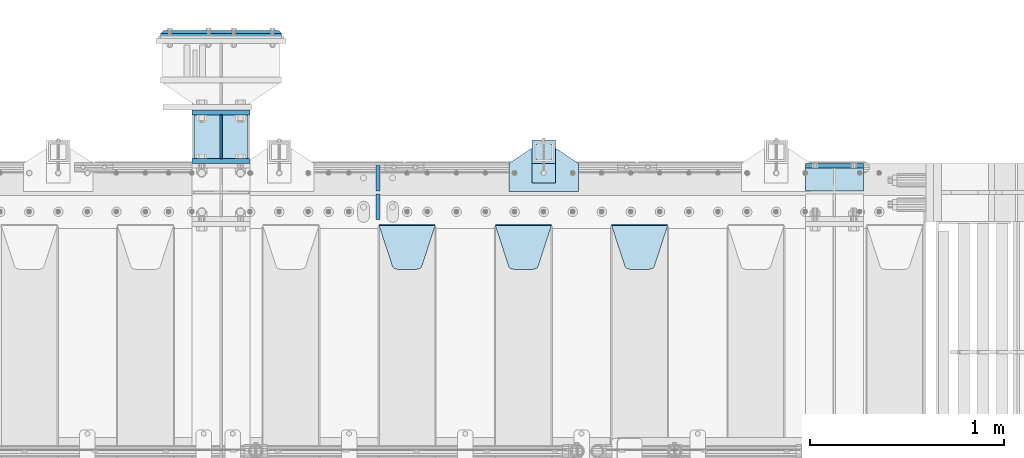
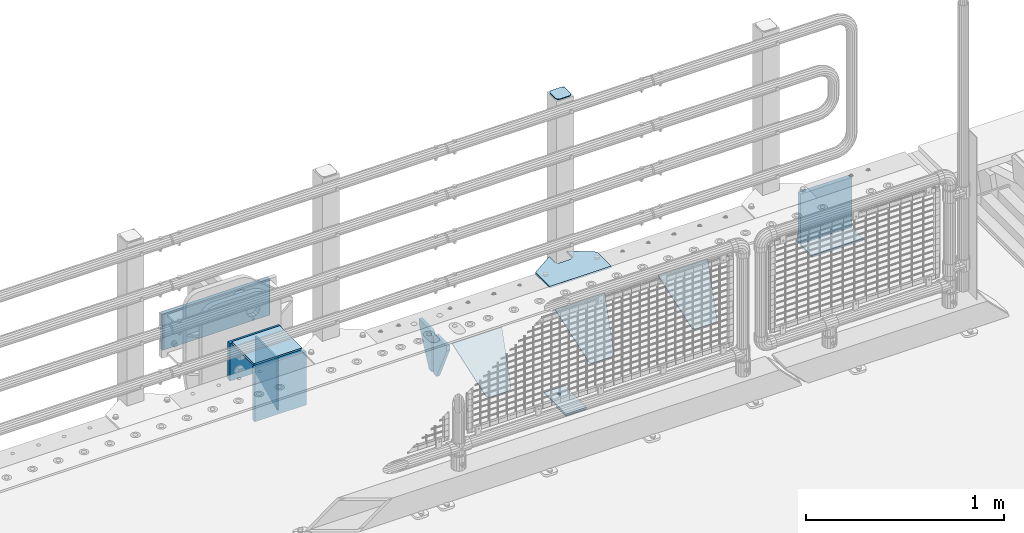
# One storey, part 226 of 240: 16 plates.
"""IFC2X3 building model written with IfcOpenShell, lengths in millimetres."""

from ifc_helpers import new_model, si_unit, frame, origin_with_axes, place, context, subcontext, project, spatial, faceted_brep, material, type_object, element, save


model = new_model("IFC2X3")

# Units and contexts
model_context = context("Model", 3, precision=1e-05, world=origin_with_axes())
body_context = subcontext(model_context, "Body", "Model", "MODEL_VIEW")
ifc_project = project(units=[si_unit("LENGTHUNIT", "METRE", prefix="MILLI"), si_unit("AREAUNIT", "SQUARE_METRE"), si_unit("VOLUMEUNIT", "CUBIC_METRE"), si_unit("MASSUNIT", "GRAM", prefix="KILO"), si_unit("TIMEUNIT", "SECOND"), si_unit("PLANEANGLEUNIT", "RADIAN"), si_unit("SOLIDANGLEUNIT", "STERADIAN"), si_unit("THERMODYNAMICTEMPERATUREUNIT", "DEGREE_CELSIUS"), si_unit("LUMINOUSINTENSITYUNIT", "LUMEN")], contexts=[model_context])

# Site, building, storey
site_placement = place(None, origin_with_axes())
site = spatial("IfcSite", under=ifc_project, at=site_placement, CompositionType="ELEMENT")
building_placement = place(site_placement, origin_with_axes())
building = spatial("IfcBuilding", under=site, at=building_placement, Name="Standard", CompositionType="ELEMENT")
storey_placement = place(building_placement, origin_with_axes())
storey = spatial("IfcBuildingStorey", under=building, at=storey_placement, Name="Undefined", CompositionType="ELEMENT", Elevation=0.0)

# Plates
ifc_material_1 = material(Name="STEEL/S355N")
plate_type_1 = type_object("IfcPlateType", PredefinedType="NOTDEFINED")
plate_1_placement = place(storey_placement, frame((55855.0, 36137.5, -339.999999999995), z_axis=(0.0, 0.0, 1.0), x_axis=(1.0, 0.0, 0.0)))
element("IfcPlate", 1, at=plate_1_placement, inside=storey, type_object=plate_type_1, material=ifc_material_1, context=body_context, shape_type="Brep", body=[
    faceted_brep([(0.0, -12.5, 0.0), (0.0, -12.5, 310.0), (0.0, 12.5, 310.0), (0.0, 12.5, 0.0), (300.0, -12.5, 310.0), (300.0, 12.5, 310.0), (300.0, -12.5, 0.0), (300.0, 12.5, 0.0)], [[[0, 1, 2, 3]], [[1, 4, 5, 2]], [[4, 6, 7, 5]], [[6, 0, 3, 7]], [[5, 7, 3, 2]], [[6, 4, 1, 0]]]),
])
plate_2_placement = place(storey_placement, frame((52690.0, 36162.5000000345, -340.000018222274), z_axis=(0.0, 0.0, 1.0), x_axis=(1.0, 0.0, 0.0)))
element("IfcPlate", 2, at=plate_2_placement, inside=storey, type_object=plate_type_1, material=ifc_material_1, context=body_context, shape_type="Brep", body=[
    faceted_brep([(0.0, -12.5, 0.0), (0.0, -12.5, 330.0), (0.0, 12.5, 330.0), (0.0, 12.5, 0.0), (300.0, -12.5, 330.0), (300.0, 12.5, 330.0), (300.0, -12.5, 0.0), (300.0, 12.5, 0.0)], [[[0, 1, 2, 3]], [[1, 4, 5, 2]], [[4, 6, 7, 5]], [[6, 0, 3, 7]], [[5, 7, 3, 2]], [[6, 4, 1, 0]]]),
])
plate_type_2 = type_object("IfcPlateType", PredefinedType="NOTDEFINED")
plate_3_placement = place(storey_placement, frame((55855.0, 36008.0, -342.999999999995), z_axis=(0.0, 1.0, 0.0), x_axis=(1.0, 0.0, 0.0)))
element("IfcPlate", 3, at=plate_3_placement, inside=storey, type_object=plate_type_2, material=ifc_material_1, context=body_context, shape_type="Brep", body=[
    faceted_brep([(0.0, -7.0, 0.0), (0.0, -7.0, 117.0), (0.0, 7.0, 117.0), (0.0, 7.0, 0.0), (300.0, -7.0, 117.0), (300.0, 7.0, 117.0), (300.0, -7.0, 0.0), (300.0, 7.0, 0.0)], [[[0, 1, 2, 3]], [[1, 4, 5, 2]], [[4, 6, 7, 5]], [[6, 0, 3, 7]], [[5, 7, 3, 2]], [[6, 4, 1, 0]]]),
])
plate_type_3 = type_object("IfcPlateType", PredefinedType="NOTDEFINED")
plate_4_placement = place(storey_placement, frame((54855.0, 35831.767766956, -1.76776695296758), z_axis=(0.0, -0.707106781186547, -0.707106781186548), x_axis=(1.0, 0.0, 0.0)))
element("IfcPlate", 4, at=plate_4_placement, inside=storey, type_object=plate_type_3, material=ifc_material_1, context=body_context, shape_type="Brep", body=[
    faceted_brep([(0.0, -2.5, 0.0), (69.345504679477, -2.50000000000364, 300.171731424827), (69.345504679477, 2.49999999999636, 300.171731424827), (0.0, 2.5, 0.0), (70.927406119954, -2.50000000000364, 304.897442415397), (70.927406119954, 2.49999999999636, 304.897442415397), (73.3818627772271, -2.50000000000728, 309.234538108525), (73.3818627772271, 2.49999999999636, 309.234538108529), (76.6187032999587, -2.50000000000728, 313.023683126099), (76.6187032999587, 2.49999999999636, 313.023683126103), (80.5190132705029, -2.50000000000364, 316.125672595368), (80.5190132705029, 2.49999999999636, 316.125672595368), (84.9395038596849, -2.50000000000364, 318.426546230472), (84.9395038596849, 2.49999999999636, 318.426546230472), (89.7177759439219, -2.5, 319.841774983277), (89.7177759439219, 2.49999999999636, 319.841774983273), (94.6782862926484, -2.50000000000364, 320.319366455074), (94.6782862926484, 2.49999999999636, 320.319366455074), (195.321713707352, -2.50000000000364, 320.319366455074), (195.321713707352, 2.49999999999636, 320.319366455074), (200.282224056078, -2.50000000000364, 319.841774983273), (200.282224056078, 2.49999999999636, 319.841774983273), (205.060496140315, -2.50000000000364, 318.426546230472), (205.060496140315, 2.49999999999636, 318.426546230472), (209.480986729497, -2.50000000000364, 316.125672595368), (209.480986729497, 2.49999999999636, 316.125672595368), (213.381296700041, -2.50000000000728, 313.023683126099), (213.381296700041, 2.49999999999272, 313.023683126099), (216.618137222766, -2.50000000000364, 309.234538108522), (216.618137222766, 2.49999999999636, 309.234538108522), (219.072593880039, -2.50000000000364, 304.897442415397), (219.072593880039, 2.49999999999636, 304.897442415397), (220.654495320523, -2.50000000000364, 300.171731424827), (220.654495320523, 2.49999999999636, 300.171731424827), (290.0, -2.50000000000364, -3.63797880709171e-12), (290.0, 2.49999999999636, -3.63797880709171e-12)], [[[0, 1, 2, 3]], [[1, 4, 5, 2]], [[4, 6, 7, 5]], [[6, 8, 9, 7]], [[8, 10, 11, 9]], [[10, 12, 13, 11]], [[12, 14, 15, 13]], [[14, 16, 17, 15]], [[16, 18, 19, 17]], [[18, 20, 21, 19]], [[20, 22, 23, 21]], [[22, 24, 25, 23]], [[24, 26, 27, 25]], [[26, 28, 29, 27]], [[28, 30, 31, 29]], [[30, 32, 33, 31]], [[32, 34, 35, 33]], [[34, 0, 3, 35]], [[5, 7, 9, 11, 13, 15, 17, 19, 21, 23, 25, 27, 29, 31, 33, 35, 3, 2]], [[34, 32, 30, 28, 26, 24, 22, 20, 18, 16, 14, 12, 10, 8, 6, 4, 1, 0]]]),
])
plate_5_placement = place(storey_placement, frame((54255.0, 35831.767766956, -1.76776695296758), z_axis=(0.0, -0.707106781186547, -0.707106781186548), x_axis=(1.0, 0.0, 0.0)))
element("IfcPlate", 5, at=plate_5_placement, inside=storey, type_object=plate_type_3, material=ifc_material_1, context=body_context, shape_type="Brep", body=[
    faceted_brep([(0.0, -2.5, 0.0), (69.345504679477, -2.50000000000364, 300.171731424827), (69.345504679477, 2.49999999999636, 300.171731424827), (0.0, 2.5, 0.0), (70.927406119954, -2.50000000000364, 304.897442415397), (70.927406119954, 2.49999999999636, 304.897442415397), (73.3818627772271, -2.50000000000728, 309.234538108525), (73.3818627772271, 2.49999999999636, 309.234538108529), (76.6187032999587, -2.50000000000728, 313.023683126099), (76.6187032999587, 2.49999999999636, 313.023683126103), (80.5190132705029, -2.50000000000364, 316.125672595368), (80.5190132705029, 2.49999999999636, 316.125672595368), (84.9395038596849, -2.50000000000364, 318.426546230472), (84.9395038596849, 2.49999999999636, 318.426546230472), (89.7177759439219, -2.5, 319.841774983277), (89.7177759439219, 2.49999999999636, 319.841774983273), (94.6782862926484, -2.50000000000364, 320.319366455074), (94.6782862926484, 2.49999999999636, 320.319366455074), (195.321713707352, -2.50000000000364, 320.319366455074), (195.321713707352, 2.49999999999636, 320.319366455074), (200.282224056078, -2.50000000000364, 319.841774983273), (200.282224056078, 2.49999999999636, 319.841774983273), (205.060496140315, -2.50000000000364, 318.426546230472), (205.060496140315, 2.49999999999636, 318.426546230472), (209.480986729497, -2.50000000000364, 316.125672595368), (209.480986729497, 2.49999999999636, 316.125672595368), (213.381296700041, -2.50000000000728, 313.023683126099), (213.381296700041, 2.49999999999272, 313.023683126099), (216.618137222766, -2.50000000000364, 309.234538108522), (216.618137222766, 2.49999999999636, 309.234538108522), (219.072593880039, -2.50000000000364, 304.897442415397), (219.072593880039, 2.49999999999636, 304.897442415397), (220.654495320523, -2.50000000000364, 300.171731424827), (220.654495320523, 2.49999999999636, 300.171731424827), (290.0, -2.50000000000364, -3.63797880709171e-12), (290.0, 2.49999999999636, -3.63797880709171e-12)], [[[0, 1, 2, 3]], [[1, 4, 5, 2]], [[4, 6, 7, 5]], [[6, 8, 9, 7]], [[8, 10, 11, 9]], [[10, 12, 13, 11]], [[12, 14, 15, 13]], [[14, 16, 17, 15]], [[16, 18, 19, 17]], [[18, 20, 21, 19]], [[20, 22, 23, 21]], [[22, 24, 25, 23]], [[24, 26, 27, 25]], [[26, 28, 29, 27]], [[28, 30, 31, 29]], [[30, 32, 33, 31]], [[32, 34, 35, 33]], [[34, 0, 3, 35]], [[5, 7, 9, 11, 13, 15, 17, 19, 21, 23, 25, 27, 29, 31, 33, 35, 3, 2]], [[34, 32, 30, 28, 26, 24, 22, 20, 18, 16, 14, 12, 10, 8, 6, 4, 1, 0]]]),
])
plate_6_placement = place(storey_placement, frame((53655.0, 35831.767766956, -1.76776695296758), z_axis=(0.0, -0.707106781186547, -0.707106781186548), x_axis=(1.0, 0.0, 0.0)))
element("IfcPlate", 6, at=plate_6_placement, inside=storey, type_object=plate_type_3, material=ifc_material_1, context=body_context, shape_type="Brep", body=[
    faceted_brep([(0.0, -2.5, 0.0), (69.345504679477, -2.50000000000364, 300.171731424827), (69.345504679477, 2.49999999999636, 300.171731424827), (0.0, 2.5, 0.0), (70.927406119954, -2.50000000000364, 304.897442415397), (70.927406119954, 2.49999999999636, 304.897442415397), (73.3818627772271, -2.50000000000728, 309.234538108525), (73.3818627772271, 2.49999999999636, 309.234538108529), (76.6187032999587, -2.50000000000728, 313.023683126099), (76.6187032999587, 2.49999999999636, 313.023683126103), (80.5190132705029, -2.50000000000364, 316.125672595368), (80.5190132705029, 2.49999999999636, 316.125672595368), (84.9395038596849, -2.50000000000364, 318.426546230472), (84.9395038596849, 2.49999999999636, 318.426546230472), (89.7177759439219, -2.5, 319.841774983277), (89.7177759439219, 2.49999999999636, 319.841774983273), (94.6782862926484, -2.50000000000364, 320.319366455074), (94.6782862926484, 2.49999999999636, 320.319366455074), (195.321713707352, -2.50000000000364, 320.319366455074), (195.321713707352, 2.49999999999636, 320.319366455074), (200.282224056078, -2.50000000000364, 319.841774983273), (200.282224056078, 2.49999999999636, 319.841774983273), (205.060496140315, -2.50000000000364, 318.426546230472), (205.060496140315, 2.49999999999636, 318.426546230472), (209.480986729497, -2.50000000000364, 316.125672595368), (209.480986729497, 2.49999999999636, 316.125672595368), (213.381296700041, -2.50000000000728, 313.023683126099), (213.381296700041, 2.49999999999272, 313.023683126099), (216.618137222766, -2.50000000000364, 309.234538108522), (216.618137222766, 2.49999999999636, 309.234538108522), (219.072593880039, -2.50000000000364, 304.897442415397), (219.072593880039, 2.49999999999636, 304.897442415397), (220.654495320523, -2.50000000000364, 300.171731424827), (220.654495320523, 2.49999999999636, 300.171731424827), (290.0, -2.50000000000364, -3.63797880709171e-12), (290.0, 2.49999999999636, -3.63797880709171e-12)], [[[0, 1, 2, 3]], [[1, 4, 5, 2]], [[4, 6, 7, 5]], [[6, 8, 9, 7]], [[8, 10, 11, 9]], [[10, 12, 13, 11]], [[12, 14, 15, 13]], [[14, 16, 17, 15]], [[16, 18, 19, 17]], [[18, 20, 21, 19]], [[20, 22, 23, 21]], [[22, 24, 25, 23]], [[24, 26, 27, 25]], [[26, 28, 29, 27]], [[28, 30, 31, 29]], [[30, 32, 33, 31]], [[32, 34, 35, 33]], [[34, 0, 3, 35]], [[5, 7, 9, 11, 13, 15, 17, 19, 21, 23, 25, 27, 29, 31, 33, 35, 3, 2]], [[34, 32, 30, 28, 26, 24, 22, 20, 18, 16, 14, 12, 10, 8, 6, 4, 1, 0]]]),
])
plate_type_4 = type_object("IfcPlateType", PredefinedType="NOTDEFINED")
for number, where, z_axis, x_axis in (
    (7, (53650.0, 36140.0, -30.0), (0.0, 0.0, -1.0), (0.0, -1.0, 0.0)),
    (8, (53650.0, 35860.0, -30.0), (0.0, 0.0, -1.0), (0.0, 1.0, 0.0)),
):
    element("IfcPlate", number, at=place(storey_placement, frame(where, z_axis=z_axis, x_axis=x_axis)), inside=storey, type_object=plate_type_4, material=ifc_material_1, context=body_context, shape_type="Brep", body=[
        faceted_brep([(0.0, -10.0, 0.0), (0.0, -10.0, 30.0), (0.0, 10.0, 30.0), (0.0, 10.0, 0.0), (102.0, -10.0, 250.0), (102.0, 10.0, 250.0), (132.0, -10.0, 250.0), (132.0, 10.0, 250.0), (132.0, -10.0, 30.0), (132.0, 10.0, 30.0), (131.544232590368, -10.0, 24.790554669992), (131.544232590368, 10.0, 24.790554669992), (130.190778623579, -10.0, 19.7393957002299), (130.190778623579, 10.0, 19.7393957002299), (127.980762113533, -10.0, 15.0), (127.980762113533, 10.0, 15.0), (124.98133329357, -10.0, 10.7163717094038), (124.98133329357, 10.0, 10.7163717094038), (121.283628290596, -10.0, 7.01866670643062), (121.283628290596, 10.0, 7.01866670643062), (117.0, -10.0, 4.01923788646684), (117.0, 10.0, 4.01923788646684), (112.260604299769, -10.0, 1.80922137642278), (112.260604299769, 10.0, 1.80922137642278), (107.209445330009, -10.0, 0.455767409633722), (107.209445330009, 10.0, 0.455767409633722), (102.0, -10.0, 0.0), (102.0, 10.0, 0.0)], [[[0, 1, 2, 3]], [[1, 4, 5, 2]], [[4, 6, 7, 5]], [[6, 8, 9, 7]], [[8, 10, 11, 9]], [[10, 12, 13, 11]], [[12, 14, 15, 13]], [[14, 16, 17, 15]], [[16, 18, 19, 17]], [[18, 20, 21, 19]], [[20, 22, 23, 21]], [[22, 24, 25, 23]], [[24, 26, 27, 25]], [[26, 0, 3, 27]], [[5, 7, 9, 11, 13, 15, 17, 19, 21, 23, 25, 27, 3, 2]], [[26, 24, 22, 20, 18, 16, 14, 12, 10, 8, 6, 4, 1, 0]]]),
    ])
ifc_material_2 = material(Name="STEEL/S355J2")
plate_type_5 = type_object("IfcPlateType", PredefinedType="NOTDEFINED")
plate_7_placement = place(storey_placement, frame((54325.0, 36005.0, 5.00000000004911), z_axis=(0.0, 1.0, 0.0), x_axis=(1.0, 0.0, 0.0)))
element("IfcPlate", 9, at=plate_7_placement, inside=storey, type_object=plate_type_5, material=ifc_material_2, context=body_context, shape_type="Brep", body=[
    faceted_brep([(0.0, -5.0, 0.0), (2.31396552408114e-06, -5.0, 145.0), (2.31396552408114e-06, 5.0, 145.0), (0.0, 5.0, 0.0), (130.0, -5.0, 230.0), (130.0, 5.0, 230.0), (130.0, -5.0, 180.0), (130.0, 5.0, 180.0), (130.48036798992, -5.0, 175.122741949599), (130.48036798992, 5.0, 175.122741949599), (131.903011687216, -5.0, 170.432914190875), (131.903011687216, 5.0, 170.432914190875), (134.213259692435, -5.0, 166.110744174512), (134.213259692435, 5.0, 166.110744174512), (137.322330470335, -5.0, 162.322330470335), (137.322330470335, 5.0, 162.322330470335), (141.110744174512, -5.0, 159.213259692435), (141.110744174512, 5.0, 159.213259692435), (145.432914190875, -5.0, 156.903011687216), (145.432914190875, 5.0, 156.903011687216), (150.122741949599, -5.0, 155.48036798992), (150.122741949599, 5.0, 155.48036798992), (155.0, -5.0, 155.0), (155.0, 5.0, 155.0), (205.0, -5.0, 155.0), (205.0, 5.0, 155.0), (209.877258050401, -5.0, 155.48036798992), (209.877258050401, 5.0, 155.48036798992), (214.567085809125, -5.0, 156.903011687216), (214.567085809125, 5.0, 156.903011687216), (218.889255825488, -5.0, 159.213259692435), (218.889255825488, 5.0, 159.213259692435), (222.677669529665, -5.0, 162.322330470335), (222.677669529665, 5.0, 162.322330470335), (225.786740307565, -5.0, 166.110744174512), (225.786740307565, 5.0, 166.110744174512), (228.096988312784, -5.0, 170.432914190875), (228.096988312784, 5.0, 170.432914190875), (229.51963201008, -5.0, 175.122741949599), (229.51963201008, 5.0, 175.122741949599), (230.0, -5.0, 180.0), (230.0, 5.0, 180.0), (230.0, -5.0, 230.0), (230.0, 5.0, 230.0), (360.0, -5.0, 145.0), (360.0, 5.0, 145.0), (360.0, -5.0, -7.27595761418343e-12), (360.0, 5.0, -7.27595761418343e-12)], [[[0, 1, 2, 3]], [[1, 4, 5, 2]], [[4, 6, 7, 5]], [[6, 8, 9, 7]], [[8, 10, 11, 9]], [[10, 12, 13, 11]], [[12, 14, 15, 13]], [[14, 16, 17, 15]], [[16, 18, 19, 17]], [[18, 20, 21, 19]], [[20, 22, 23, 21]], [[22, 24, 25, 23]], [[24, 26, 27, 25]], [[26, 28, 29, 27]], [[28, 30, 31, 29]], [[30, 32, 33, 31]], [[32, 34, 35, 33]], [[34, 36, 37, 35]], [[36, 38, 39, 37]], [[38, 40, 41, 39]], [[40, 42, 43, 41]], [[42, 44, 45, 43]], [[44, 46, 47, 45]], [[46, 0, 3, 47]], [[5, 7, 9, 11, 13, 15, 17, 19, 21, 23, 25, 27, 29, 31, 33, 35, 37, 39, 41, 43, 45, 47, 3, 2]], [[46, 44, 42, 40, 38, 36, 34, 32, 30, 28, 26, 24, 22, 20, 18, 16, 14, 12, 10, 8, 6, 4, 1, 0]]]),
])
plate_type_6 = type_object("IfcPlateType", PredefinedType="NOTDEFINED")
plate_8_placement = place(storey_placement, frame((54445.0000000001, 36050.0000000002, -850.000000000002), z_axis=(0.0, 1.0, 0.0), x_axis=(1.0, 0.0, 0.0)))
element("IfcPlate", 10, at=plate_8_placement, inside=storey, type_object=plate_type_6, material=ifc_material_2, context=body_context, shape_type="Brep", body=[
    faceted_brep([(66.3639610305399, -5.0, 163.636038969111), (66.3639610305399, 5.0, 163.636038969111), (59.9999999998618, 5.0, 160.999999999789), (59.9999999998618, -5.0, 160.999999999789), (53.6360389691836, 5.0, 163.636038969111), (53.6360389691836, -5.0, 163.636038969111), (50.9999999998618, 5.0, 169.999999999789), (50.9999999998618, -5.0, 169.999999999789), (53.6360389691836, 5.0, 176.363961030467), (53.6360389691836, -5.0, 176.363961030467), (59.9999999998618, 5.0, 178.999999999789), (59.9999999998618, -5.0, 178.999999999789), (66.3639610305399, 5.0, 176.363961030467), (66.3639610305399, -5.0, 176.363961030467), (68.9999999998618, 5.0, 169.999999999789), (68.9999999998618, -5.0, 169.999999999789), (120.0, -5.0, 0.0), (120.0, -5.0, 220.0), (0.0, -5.0, 220.0), (0.0, -5.0, 0.0), (0.0, 5.0, 0.0), (120.0, 5.0, 0.0), (120.0, 5.0, 220.0), (0.0, 5.0, 220.0)], [[[0, 1, 2, 3]], [[3, 2, 4, 5]], [[5, 4, 6, 7]], [[7, 6, 8, 9]], [[9, 8, 10, 11]], [[11, 10, 12, 13]], [[13, 12, 14, 15]], [[15, 14, 1, 0]], [[16, 17, 18, 19], [3, 5, 7, 9, 11, 13, 15, 0]], [[16, 19, 20, 21]], [[17, 16, 21, 22]], [[18, 17, 22, 23]], [[19, 18, 23, 20]], [[22, 21, 20, 23], [10, 8, 6, 4, 2, 1, 14, 12]]]),
])
plate_type_7 = type_object("IfcPlateType", PredefinedType="NOTDEFINED")
plate_9_placement = place(storey_placement, frame((54549.0000000001, 36166.0000000002, 1012.50000000001), z_axis=(0.0, 1.0, 0.0), x_axis=(-1.0, 0.0, 0.0)))
element("IfcPlate", 11, at=plate_9_placement, inside=storey, type_object=plate_type_7, material=ifc_material_2, context=body_context, shape_type="Brep", body=[
    faceted_brep([(0.0, -2.5, 19.0), (0.0, -2.5, 69.0), (0.0, 2.5, 69.0), (0.0, 2.5, 19.0), (0.476369668547704, -2.5, 73.2278977451715), (0.476369668547704, 2.5, 73.2278977451715), (1.88159150985302, -2.5, 77.2437910432345), (1.88159150985302, 2.5, 77.2437910432345), (4.14520183311106, -2.5, 80.8463062353185), (4.14520183311106, 2.5, 80.8463062353185), (7.15369376468152, -2.5, 83.8547981668889), (7.15369376468152, 2.5, 83.8547981668889), (10.7562089567655, -2.5, 86.118408490147), (10.7562089567655, 2.5, 86.118408490147), (14.7721022548285, -2.5, 87.5236303314523), (14.7721022548285, 2.5, 87.5236303314523), (19.0, -2.5, 88.0), (19.0, 2.5, 88.0), (69.0, -2.5, 88.0), (69.0, 2.5, 88.0), (73.2278977451715, -2.5, 87.5236303314523), (73.2278977451715, 2.5, 87.5236303314523), (77.2437910432345, -2.5, 86.118408490147), (77.2437910432345, 2.5, 86.118408490147), (80.8463062353185, -2.5, 83.8547981668889), (80.8463062353185, 2.5, 83.8547981668889), (83.8547981668889, -2.5, 80.8463062353185), (83.8547981668889, 2.5, 80.8463062353185), (86.118408490147, -2.5, 77.2437910432345), (86.118408490147, 2.5, 77.2437910432345), (87.5236303314523, -2.5, 73.2278977451715), (87.5236303314523, 2.5, 73.2278977451715), (88.0, -2.5, 69.0), (88.0, 2.5, 69.0), (88.0, -2.5, 19.0), (88.0, 2.5, 19.0), (87.5236303314523, -2.5, 14.7721022548285), (87.5236303314523, 2.5, 14.7721022548285), (86.118408490147, -2.5, 10.7562089567655), (86.118408490147, 2.5, 10.7562089567655), (83.8547981668889, -2.5, 7.15369376468152), (83.8547981668889, 2.5, 7.15369376468152), (80.8463062353185, -2.5, 4.14520183311106), (80.8463062353185, 2.5, 4.14520183311106), (77.2437910432345, -2.5, 1.88159150985302), (77.2437910432345, 2.5, 1.88159150985302), (73.2278977451715, -2.5, 0.476369668547704), (73.2278977451715, 2.5, 0.476369668547704), (69.0, -2.5, 0.0), (69.0, 2.5, 0.0), (19.0, -2.5, 0.0), (19.0, 2.5, 0.0), (14.7721022548285, -2.5, 0.476369668547704), (14.7721022548285, 2.5, 0.476369668547704), (10.7562089567655, -2.5, 1.88159150985302), (10.7562089567655, 2.5, 1.88159150985302), (7.15369376468152, -2.5, 4.14520183311106), (7.15369376468152, 2.5, 4.14520183311106), (4.14520183311106, -2.5, 7.15369376468152), (4.14520183311106, 2.5, 7.15369376468152), (1.88159150985302, -2.5, 10.7562089567655), (1.88159150985302, 2.5, 10.7562089567655), (0.476369668547704, -2.5, 14.7721022548285), (0.476369668547704, 2.5, 14.7721022548285)], [[[0, 1, 2, 3]], [[1, 4, 5, 2]], [[4, 6, 7, 5]], [[6, 8, 9, 7]], [[8, 10, 11, 9]], [[10, 12, 13, 11]], [[12, 14, 15, 13]], [[14, 16, 17, 15]], [[16, 18, 19, 17]], [[18, 20, 21, 19]], [[20, 22, 23, 21]], [[22, 24, 25, 23]], [[24, 26, 27, 25]], [[26, 28, 29, 27]], [[28, 30, 31, 29]], [[30, 32, 33, 31]], [[32, 34, 35, 33]], [[34, 36, 37, 35]], [[36, 38, 39, 37]], [[38, 40, 41, 39]], [[40, 42, 43, 41]], [[42, 44, 45, 43]], [[44, 46, 47, 45]], [[46, 48, 49, 47]], [[48, 50, 51, 49]], [[50, 52, 53, 51]], [[52, 54, 55, 53]], [[54, 56, 57, 55]], [[56, 58, 59, 57]], [[58, 60, 61, 59]], [[60, 62, 63, 61]], [[62, 0, 3, 63]], [[5, 7, 9, 11, 13, 15, 17, 19, 21, 23, 25, 27, 29, 31, 33, 35, 37, 39, 41, 43, 45, 47, 49, 51, 53, 55, 57, 59, 61, 63, 3, 2]], [[62, 60, 58, 56, 54, 52, 50, 48, 46, 44, 42, 40, 38, 36, 34, 32, 30, 28, 26, 24, 22, 20, 18, 16, 14, 12, 10, 8, 6, 4, 1, 0]]]),
])
plate_type_8 = type_object("IfcPlateType", PredefinedType="NOTDEFINED")
plate_10_placement = place(storey_placement, frame((54445.0000000001, 36050.0000000002, -857.500000000002), z_axis=(0.0, 1.0, 0.0), x_axis=(1.0, 0.0, 0.0)))
element("IfcPlate", 12, at=plate_10_placement, inside=storey, type_object=plate_type_8, material=ifc_material_2, context=body_context, shape_type="Brep", body=[
    faceted_brep([(0.0, -2.5, 0.0), (0.0, -2.5, 100.0), (0.0, 2.5, 100.0), (0.0, 2.5, 0.0), (120.0, -2.5, 100.0), (120.0, 2.5, 100.0), (120.0, -2.5, 0.0), (120.0, 2.5, 0.0)], [[[0, 1, 2, 3]], [[1, 4, 5, 2]], [[4, 6, 7, 5]], [[6, 0, 3, 7]], [[5, 7, 3, 2]], [[6, 4, 1, 0]]]),
])
ifc_material_3 = material()
plate_type_9 = type_object("IfcPlateType", PredefinedType="NOTDEFINED")
plate_11_placement = place(storey_placement, frame((53152.5, 36815.0000000345, -12.500018222274), z_axis=(0.0, 0.0, -1.0), x_axis=(-1.0, 0.0, 0.0)))
element("IfcPlate", 13, at=plate_11_placement, inside=storey, type_object=plate_type_9, material=ifc_material_3, context=body_context, shape_type="Brep", body=[
    faceted_brep([(0.0, -15.0, 0.0), (5.0, -20.0, 5.0), (5.0, -20.0, 220.0), (0.0, -15.0, 225.0), (625.0, -15.0, 0.0), (620.0, -20.0, 5.0), (620.0, -20.0, 220.0), (625.0, -15.0, 225.0), (15.0, 20.0, 15.0), (0.0, 5.0, 0.0), (0.0, 5.0, 225.0), (15.0, 20.0, 210.0), (625.0, 5.0, 225.0), (610.0, 20.0, 210.0), (625.0, 5.0, 0.0), (610.0, 20.0, 15.0), (64.8205080756888, -5.0, 167.5), (57.5, -5.0, 160.179491924311), (47.5, -5.0, 157.5), (37.5, -5.0, 160.179491924311), (30.1794919243112, -5.0, 167.5), (27.5, -5.0, 177.5), (30.1794919243112, -5.0, 187.5), (37.5, -5.0, 194.820508075689), (47.5, -5.0, 197.5), (57.5, -5.0, 194.820508075689), (64.8205080756888, -5.0, 187.5), (67.5, -5.0, 177.5), (37.5, 20.0, 194.820508075689), (30.1794919243112, 20.0, 187.5), (47.5, 20.0, 197.5), (57.5, 20.0, 194.820508075689), (64.8205080756888, 20.0, 187.5), (67.5, 20.0, 177.5), (64.8205080756888, 20.0, 167.5), (57.5, 20.0, 160.179491924311), (47.5, 20.0, 157.5), (37.5, 20.0, 160.179491924311), (30.1794919243112, 20.0, 167.5), (27.5, 20.0, 177.5), (64.8205080756888, -5.0, 37.5), (57.5, -5.0, 30.1794919243112), (47.5, -5.0, 27.5), (37.5, -5.0, 30.1794919243112), (30.1794919243112, -5.0, 37.5), (27.5, -5.0, 47.5), (30.1794919243112, -5.0, 57.5), (37.5, -5.0, 64.8205080756888), (47.5, -5.0, 67.5), (57.5, -5.0, 64.8205080756888), (64.8205080756888, -5.0, 57.5), (67.5, -5.0, 47.5), (30.1794919243112, 20.0, 57.5), (27.5, 20.0, 47.5), (37.5, 20.0, 64.8205080756888), (47.5, 20.0, 67.5), (57.5, 20.0, 64.8205080756888), (64.8205080756888, 20.0, 57.5), (67.5, 20.0, 47.5), (64.8205080756888, 20.0, 37.5), (57.5, 20.0, 30.1794919243112), (47.5, 20.0, 27.5), (37.5, 20.0, 30.1794919243112), (30.1794919243112, 20.0, 37.5), (264.820508075689, -5.0, 37.5), (257.5, -5.0, 30.1794919243112), (247.5, -5.0, 27.5), (237.5, -5.0, 30.1794919243112), (230.179491924311, -5.0, 37.5), (227.5, -5.0, 47.5), (230.179491924311, -5.0, 57.5), (237.5, -5.0, 64.8205080756888), (247.5, -5.0, 67.5), (257.5, -5.0, 64.8205080756888), (264.820508075689, -5.0, 57.5), (267.5, -5.0, 47.5), (230.179491924311, 20.0, 57.5), (227.5, 20.0, 47.5), (237.5, 20.0, 64.8205080756888), (247.5, 20.0, 67.5), (257.5, 20.0, 64.8205080756888), (264.820508075689, 20.0, 57.5), (267.5, 20.0, 47.5), (264.820508075689, 20.0, 37.5), (257.5, 20.0, 30.1794919243112), (247.5, 20.0, 27.5), (237.5, 20.0, 30.1794919243112), (230.179491924311, 20.0, 37.5), (394.820508075689, -5.0, 37.5), (387.5, -5.0, 30.1794919243112), (377.5, -5.0, 27.5), (367.5, -5.0, 30.1794919243112), (360.179491924311, -5.0, 37.5), (357.5, -5.0, 47.5), (360.179491924311, -5.0, 57.5), (367.5, -5.0, 64.8205080756888), (377.5, -5.0, 67.5), (387.5, -5.0, 64.8205080756888), (394.820508075689, -5.0, 57.5), (397.5, -5.0, 47.5), (360.179491924311, 20.0, 57.5), (357.5, 20.0, 47.5), (367.5, 20.0, 64.8205080756888), (377.5, 20.0, 67.5), (387.5, 20.0, 64.8205080756888), (394.820508075689, 20.0, 57.5), (397.5, 20.0, 47.5), (394.820508075689, 20.0, 37.5), (387.5, 20.0, 30.1794919243112), (377.5, 20.0, 27.5), (367.5, 20.0, 30.1794919243112), (360.179491924311, 20.0, 37.5), (594.820508075689, -5.0, 37.5), (587.5, -5.0, 30.1794919243112), (577.5, -5.0, 27.5), (567.5, -5.0, 30.1794919243112), (560.179491924311, -5.0, 37.5), (557.5, -5.0, 47.5), (560.179491924311, -5.0, 57.5), (567.5, -5.0, 64.8205080756888), (577.5, -5.0, 67.5), (587.5, -5.0, 64.8205080756888), (594.820508075689, -5.0, 57.5), (597.5, -5.0, 47.5), (560.179491924311, 20.0, 57.5), (557.5, 20.0, 47.5), (567.5, 20.0, 64.8205080756888), (577.5, 20.0, 67.5), (587.5, 20.0, 64.8205080756888), (594.820508075689, 20.0, 57.5), (597.5, 20.0, 47.5), (594.820508075689, 20.0, 37.5), (587.5, 20.0, 30.1794919243112), (577.5, 20.0, 27.5), (567.5, 20.0, 30.1794919243112), (560.179491924311, 20.0, 37.5), (594.820508075689, -5.0, 167.5), (587.5, -5.0, 160.179491924311), (577.5, -5.0, 157.5), (567.5, -5.0, 160.179491924311), (560.179491924311, -5.0, 167.5), (557.5, -5.0, 177.5), (560.179491924311, -5.0, 187.5), (567.5, -5.0, 194.820508075689), (577.5, -5.0, 197.5), (587.5, -5.0, 194.820508075689), (594.820508075689, -5.0, 187.5), (597.5, -5.0, 177.5), (560.179491924311, 20.0, 187.5), (557.5, 20.0, 177.5), (567.5, 20.0, 194.820508075689), (577.5, 20.0, 197.5), (587.5, 20.0, 194.820508075689), (594.820508075689, 20.0, 187.5), (597.5, 20.0, 177.5), (594.820508075689, 20.0, 167.5), (587.5, 20.0, 160.179491924311), (577.5, 20.0, 157.5), (567.5, 20.0, 160.179491924311), (560.179491924311, 20.0, 167.5), (394.820508075689, -5.0, 167.5), (387.5, -5.0, 160.179491924311), (377.5, -5.0, 157.5), (367.5, -5.0, 160.179491924311), (360.179491924311, -5.0, 167.5), (357.5, -5.0, 177.5), (360.179491924311, -5.0, 187.5), (367.5, -5.0, 194.820508075689), (377.5, -5.0, 197.5), (387.5, -5.0, 194.820508075689), (394.820508075689, -5.0, 187.5), (397.5, -5.0, 177.5), (360.179491924311, 20.0, 187.5), (357.5, 20.0, 177.5), (367.5, 20.0, 194.820508075689), (377.5, 20.0, 197.5), (387.5, 20.0, 194.820508075689), (394.820508075689, 20.0, 187.5), (397.5, 20.0, 177.5), (394.820508075689, 20.0, 167.5), (387.5, 20.0, 160.179491924311), (377.5, 20.0, 157.5), (367.5, 20.0, 160.179491924311), (360.179491924311, 20.0, 167.5), (264.820508075689, -5.0, 167.5), (257.5, -5.0, 160.179491924311), (247.5, -5.0, 157.5), (237.5, -5.0, 160.179491924311), (230.179491924311, -5.0, 167.5), (227.5, -5.0, 177.5), (230.179491924311, -5.0, 187.5), (237.5, -5.0, 194.820508075689), (247.5, -5.0, 197.5), (257.5, -5.0, 194.820508075689), (264.820508075689, -5.0, 187.5), (267.5, -5.0, 177.5), (230.179491924311, 20.0, 187.5), (227.5, 20.0, 177.5), (237.5, 20.0, 194.820508075689), (247.5, 20.0, 197.5), (257.5, 20.0, 194.820508075689), (264.820508075689, 20.0, 187.5), (267.5, 20.0, 177.5), (264.820508075689, 20.0, 167.5), (257.5, 20.0, 160.179491924311), (247.5, 20.0, 157.5), (237.5, 20.0, 160.179491924311), (230.179491924311, 20.0, 167.5)], [[[0, 1, 2, 3]], [[4, 5, 1, 0]], [[6, 7, 3, 2]], [[7, 6, 5, 4]], [[8, 9, 10, 11]], [[12, 13, 11, 10]], [[14, 15, 13, 12]], [[15, 14, 9, 8]], [[16, 17, 18, 19, 20, 21, 22, 23, 24, 25, 26, 27]], [[28, 23, 22, 29]], [[30, 24, 23, 28]], [[31, 25, 24, 30]], [[32, 26, 25, 31]], [[33, 27, 26, 32]], [[34, 16, 27, 33]], [[35, 17, 16, 34]], [[36, 18, 17, 35]], [[37, 19, 18, 36]], [[38, 20, 19, 37]], [[39, 21, 20, 38]], [[29, 22, 21, 39]], [[5, 6, 2, 1]], [[9, 14, 4, 0]], [[14, 12, 7, 4]], [[12, 10, 3, 7]], [[10, 9, 0, 3]], [[40, 41, 42, 43, 44, 45, 46, 47, 48, 49, 50, 51]], [[52, 46, 45, 53]], [[54, 47, 46, 52]], [[55, 48, 47, 54]], [[56, 49, 48, 55]], [[57, 50, 49, 56]], [[58, 51, 50, 57]], [[59, 40, 51, 58]], [[60, 41, 40, 59]], [[61, 42, 41, 60]], [[62, 43, 42, 61]], [[63, 44, 43, 62]], [[53, 45, 44, 63]], [[64, 65, 66, 67, 68, 69, 70, 71, 72, 73, 74, 75]], [[76, 70, 69, 77]], [[78, 71, 70, 76]], [[79, 72, 71, 78]], [[80, 73, 72, 79]], [[81, 74, 73, 80]], [[82, 75, 74, 81]], [[83, 64, 75, 82]], [[84, 65, 64, 83]], [[85, 66, 65, 84]], [[86, 67, 66, 85]], [[87, 68, 67, 86]], [[77, 69, 68, 87]], [[88, 89, 90, 91, 92, 93, 94, 95, 96, 97, 98, 99]], [[100, 94, 93, 101]], [[102, 95, 94, 100]], [[103, 96, 95, 102]], [[104, 97, 96, 103]], [[105, 98, 97, 104]], [[106, 99, 98, 105]], [[107, 88, 99, 106]], [[108, 89, 88, 107]], [[109, 90, 89, 108]], [[110, 91, 90, 109]], [[111, 92, 91, 110]], [[101, 93, 92, 111]], [[112, 113, 114, 115, 116, 117, 118, 119, 120, 121, 122, 123]], [[124, 118, 117, 125]], [[126, 119, 118, 124]], [[127, 120, 119, 126]], [[128, 121, 120, 127]], [[129, 122, 121, 128]], [[130, 123, 122, 129]], [[131, 112, 123, 130]], [[132, 113, 112, 131]], [[133, 114, 113, 132]], [[134, 115, 114, 133]], [[135, 116, 115, 134]], [[125, 117, 116, 135]], [[136, 137, 138, 139, 140, 141, 142, 143, 144, 145, 146, 147]], [[148, 142, 141, 149]], [[150, 143, 142, 148]], [[151, 144, 143, 150]], [[152, 145, 144, 151]], [[153, 146, 145, 152]], [[154, 147, 146, 153]], [[155, 136, 147, 154]], [[156, 137, 136, 155]], [[157, 138, 137, 156]], [[158, 139, 138, 157]], [[159, 140, 139, 158]], [[149, 141, 140, 159]], [[160, 161, 162, 163, 164, 165, 166, 167, 168, 169, 170, 171]], [[172, 166, 165, 173]], [[174, 167, 166, 172]], [[175, 168, 167, 174]], [[176, 169, 168, 175]], [[177, 170, 169, 176]], [[178, 171, 170, 177]], [[179, 160, 171, 178]], [[180, 161, 160, 179]], [[181, 162, 161, 180]], [[182, 163, 162, 181]], [[183, 164, 163, 182]], [[173, 165, 164, 183]], [[184, 185, 186, 187, 188, 189, 190, 191, 192, 193, 194, 195]], [[196, 190, 189, 197]], [[198, 191, 190, 196]], [[199, 192, 191, 198]], [[200, 193, 192, 199]], [[201, 194, 193, 200]], [[202, 195, 194, 201]], [[203, 184, 195, 202]], [[204, 185, 184, 203]], [[205, 186, 185, 204]], [[206, 187, 186, 205]], [[207, 188, 187, 206]], [[197, 189, 188, 207]], [[13, 15, 8, 11], [37, 36, 35, 34, 33, 32, 31, 30, 28, 29, 39, 38], [206, 205, 204, 203, 202, 201, 200, 199, 198, 196, 197, 207], [182, 181, 180, 179, 178, 177, 176, 175, 174, 172, 173, 183], [158, 157, 156, 155, 154, 153, 152, 151, 150, 148, 149, 159], [134, 133, 132, 131, 130, 129, 128, 127, 126, 124, 125, 135], [110, 109, 108, 107, 106, 105, 104, 103, 102, 100, 101, 111], [86, 85, 84, 83, 82, 81, 80, 79, 78, 76, 77, 87], [62, 61, 60, 59, 58, 57, 56, 55, 54, 52, 53, 63]]]),
])
plate_type_10 = type_object("IfcPlateType", PredefinedType="NOTDEFINED")
plate_12_placement = place(storey_placement, frame((52690.0, 36412.5000000345, -240.000018222274), z_axis=(0.0, 0.0, 1.0), x_axis=(1.0, 0.0, 0.0)))
element("IfcPlate", 14, at=plate_12_placement, inside=storey, type_object=plate_type_10, material=ifc_material_1, context=body_context, shape_type="Brep", body=[
    faceted_brep([(0.0, -12.5, 0.0), (0.0, -12.5, 230.0), (0.0, 12.5, 230.0), (0.0, 12.5, 0.0), (300.0, -12.5, 230.0), (300.0, 12.5, 230.0), (300.0, -12.5, 0.0), (300.0, 12.5, 0.0)], [[[0, 1, 2, 3]], [[1, 4, 5, 2]], [[4, 6, 7, 5]], [[6, 0, 3, 7]], [[5, 7, 3, 2]], [[6, 4, 1, 0]]]),
])
plate_type_11 = type_object("IfcPlateType", PredefinedType="NOTDEFINED")
plate_13_placement = place(storey_placement, frame((52840.0, 36175.0000000345, -336.000018222274), z_axis=(0.0, 1.0, 0.0), x_axis=(0.0, 0.0, 1.0)))
element("IfcPlate", 15, at=plate_13_placement, inside=storey, type_object=plate_type_11, material=ifc_material_1, context=body_context, shape_type="Brep", body=[
    faceted_brep([(0.0, -5.0, 0.0), (100.0, -5.0, 225.0), (100.0, 5.0, 225.0), (0.0, 5.0, 0.0), (322.0, -5.0, 225.0), (322.0, 5.0, 225.0), (322.0, -5.0, 0.0), (322.0, 5.0, 0.0)], [[[0, 1, 2, 3]], [[1, 4, 5, 2]], [[4, 6, 7, 5]], [[6, 0, 3, 7]], [[5, 7, 3, 2]], [[6, 4, 1, 0]]]),
])
plate_type_12 = type_object("IfcPlateType", PredefinedType="NOTDEFINED")
plate_14_placement = place(storey_placement, frame((52700.0, 36175.0000000345, -7.00001822227398), z_axis=(0.0, 1.0, 0.0), x_axis=(1.0, 0.0, 0.0)))
element("IfcPlate", 16, at=plate_14_placement, inside=storey, type_object=plate_type_12, material=ifc_material_1, context=body_context, shape_type="Brep", body=[
    faceted_brep([(0.0, -7.0, 0.0), (0.0, -7.0, 225.0), (0.0, 7.0, 225.0), (0.0, 7.0, 0.0), (280.0, -7.0, 225.0), (280.0, 7.0, 225.0), (280.0, -6.99999999999818, 0.0), (280.0, 7.0, 0.0)], [[[0, 1, 2, 3]], [[1, 4, 5, 2]], [[4, 6, 7, 5]], [[6, 0, 3, 7]], [[5, 7, 3, 2]], [[6, 4, 1, 0]]]),
])

save(model, "model.ifc")
